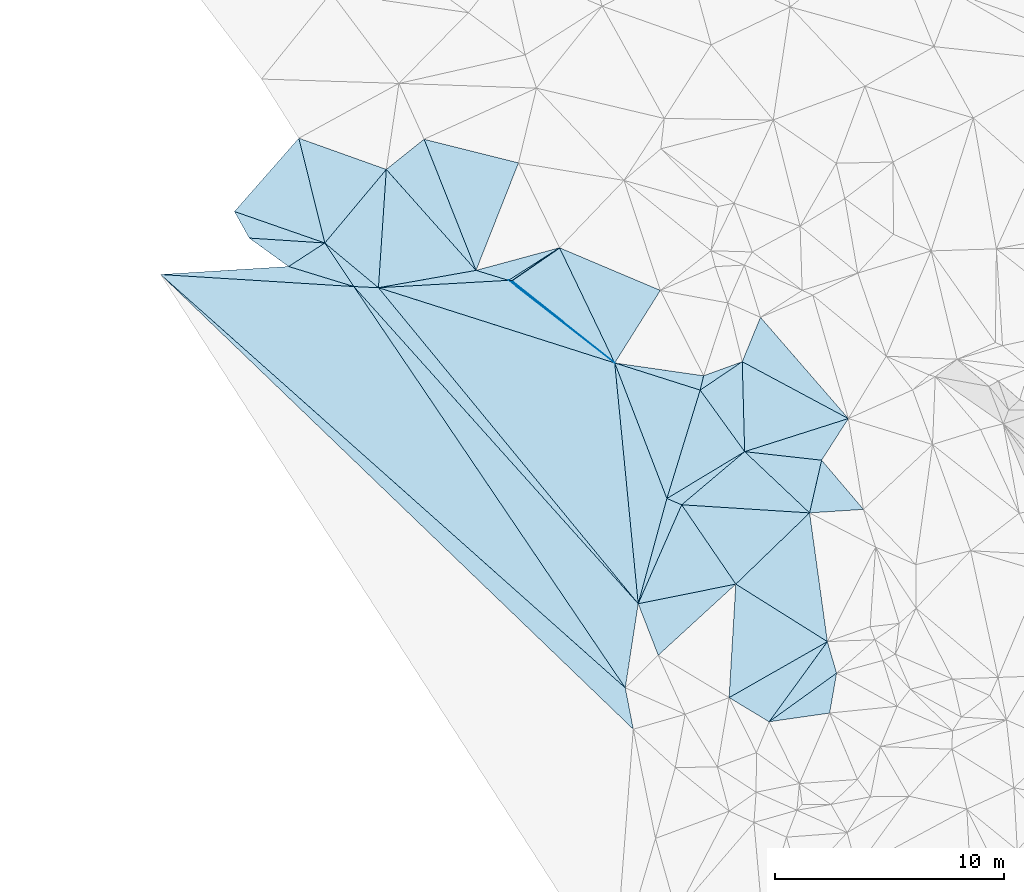
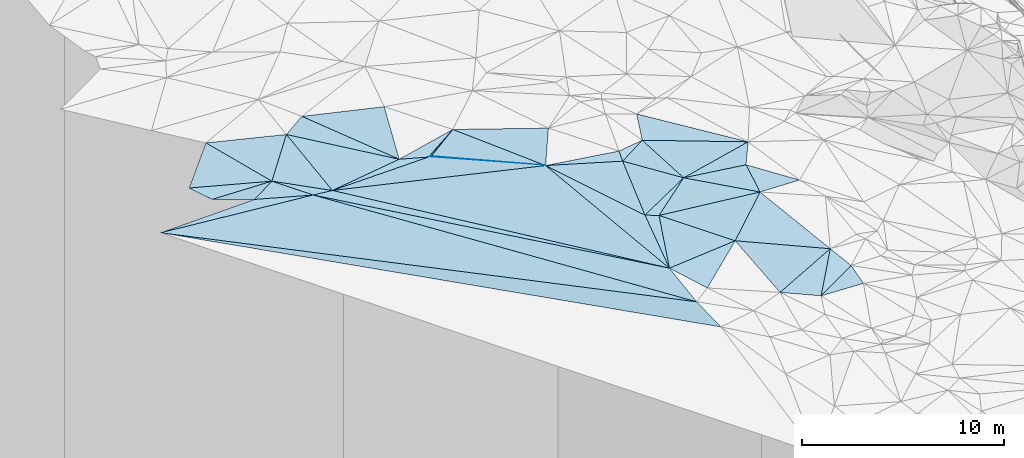
# One storey, part 10 of 275: 45 plates.
"""IFC2X3 building model written with IfcOpenShell, lengths in millimetres."""

from ifc_helpers import new_model, si_unit, frame, origin_with_axes, place, context, subcontext, project, spatial, polyline, outline, extrude, material, type_object, element, save


model = new_model("IFC2X3")

# Units and contexts
model_context = context("Model", 3, precision=1e-05, world=origin_with_axes())
body_context = subcontext(model_context, "Body", "Model", "MODEL_VIEW")
ifc_project = project(units=[si_unit("LENGTHUNIT", "METRE", prefix="MILLI"), si_unit("AREAUNIT", "SQUARE_METRE"), si_unit("VOLUMEUNIT", "CUBIC_METRE"), si_unit("MASSUNIT", "GRAM", prefix="KILO"), si_unit("TIMEUNIT", "SECOND"), si_unit("PLANEANGLEUNIT", "RADIAN"), si_unit("SOLIDANGLEUNIT", "STERADIAN"), si_unit("THERMODYNAMICTEMPERATUREUNIT", "DEGREE_CELSIUS"), si_unit("LUMINOUSINTENSITYUNIT", "LUMEN")], contexts=[model_context])

# Site, building, storey
site_placement = place(None, origin_with_axes())
site = spatial("IfcSite", under=ifc_project, at=site_placement, CompositionType="ELEMENT")
building_placement = place(site_placement, origin_with_axes())
building = spatial("IfcBuilding", under=site, at=building_placement, Name="Undefined", CompositionType="ELEMENT")
storey_placement = place(building_placement, origin_with_axes())
storey = spatial("IfcBuildingStorey", under=building, at=storey_placement, Name="Undefined", CompositionType="ELEMENT", Elevation=0.0)

# Plates
ifc_material = material()
plate_type_1 = type_object("IfcPlateType", PredefinedType="NOTDEFINED")
plate_1_placement = place(storey_placement, frame((-129497.98944048, 30765.4203278854, 46839.5020352332), z_axis=(0.057981187811851, -0.0697690065833723, -0.995876733125288), x_axis=(0.842744180886852, 0.538194366656215, 0.0113608662022535)))
element("IfcPlate", 1, at=plate_1_placement, inside=storey, type_object=plate_type_1, material=ifc_material, Name="00", context=body_context, shape_type="SweptSolid", body=[
    extrude(outline(polyline([(0.0, 0.0), (2640.64379882813, 4.32191882282496e-09), (106.60279083252, 97.6516571044922), (0.0, 0.0)])), frame((-8.85201319254618e-08, 2.18876761149539e-07, -0.5000001331573), z_axis=(0.0, 0.0, 1.0), x_axis=(1.0, 0.0, 0.0)), (0.0, 0.0, 1.0), 1.0),
])
plate_type_2 = type_object("IfcPlateType", PredefinedType="NOTDEFINED")
plate_2_placement = place(storey_placement, frame((-140809.419800372, 32609.296453986, 47119.5102054351), z_axis=(0.0366322844317989, 0.197863868701797, -0.979544774474177), x_axis=(-0.479506587570153, 0.863473031622803, 0.156485641951436)))
element("IfcPlate", 2, at=plate_2_placement, inside=storey, type_object=plate_type_2, material=ifc_material, Name="00", context=body_context, shape_type="SweptSolid", body=[
    extrude(outline(polyline([(0.0, 0.0), (1341.97619628906, -7.69796315580606e-09), (-1754.42761230469, 2802.53173828125), (0.0, 0.0)])), frame((-8.85201319254618e-08, 2.18876761149539e-07, -0.5000001331573), z_axis=(0.0, 0.0, 1.0), x_axis=(1.0, 0.0, 0.0)), (0.0, 0.0, 1.0), 1.0),
])
plate_type_3 = type_object("IfcPlateType", PredefinedType="NOTDEFINED")
plate_3_placement = place(storey_placement, frame((-115186.898183382, 13628.7321359164, 45659.505493286), z_axis=(-0.146868596418924, -0.0199757192000354, -0.988954289150099), x_axis=(-0.170723624477364, -0.984280047524368, 0.045235296956477)))
element("IfcPlate", 3, at=plate_3_placement, inside=storey, type_object=plate_type_3, material=ifc_material, Name="00", context=body_context, shape_type="SweptSolid", body=[
    extrude(outline(polyline([(0.0, 0.0), (1768.53051757813, 8.73114913702011e-11), (2612.28173828125, 2563.47094726563), (0.0, 0.0)])), frame((-8.85201319254618e-08, 2.18876761149539e-07, -0.5000001331573), z_axis=(0.0, 0.0, 1.0), x_axis=(1.0, 0.0, 0.0)), (0.0, 0.0, 1.0), 1.0),
])
plate_type_4 = type_object("IfcPlateType", PredefinedType="NOTDEFINED")
plate_4_placement = place(storey_placement, frame((-136244.554453764, 30494.4167340226, 47069.5011180862), z_axis=(-0.0617956592439033, 0.0270720044025747, -0.997721605998506), x_axis=(-0.953826144430841, 0.29278631743481, 0.0670213288674469)))
element("IfcPlate", 4, at=plate_4_placement, inside=storey, type_object=plate_type_4, material=ifc_material, Name="00", context=body_context, shape_type="SweptSolid", body=[
    extrude(outline(polyline([(0.0, 0.0), (2984.12475585938, -7.31779437046498e-09), (1773.04919433594, 1444.9208984375), (0.0, 0.0)])), frame((-8.85201319254618e-08, 2.18876761149539e-07, -0.5000001331573), z_axis=(0.0, 0.0, 1.0), x_axis=(1.0, 0.0, 0.0)), (0.0, 0.0, 1.0), 1.0),
])
plate_type_5 = type_object("IfcPlateType", PredefinedType="NOTDEFINED")
plate_5_placement = place(storey_placement, frame((-120987.42116318, 26601.1872303956, 46749.5193984975), z_axis=(0.00514777234642593, 0.275952058057676, -0.961157615635231), x_axis=(-0.225682846420036, -0.936051686110689, -0.269952762091974)))
element("IfcPlate", 5, at=plate_5_placement, inside=storey, type_object=plate_type_5, material=ifc_material, Name="00", context=body_context, shape_type="SweptSolid", body=[
    extrude(outline(polyline([(0.0, 0.0), (666.783325195313, -2.3283064365387e-10), (313.145202636719, 3907.72827148438), (0.0, 0.0)])), frame((-8.85201319254618e-08, 2.18876761149539e-07, -0.5000001331573), z_axis=(0.0, 0.0, 1.0), x_axis=(1.0, 0.0, 0.0)), (0.0, 0.0, 1.0), 1.0),
])
plate_type_6 = type_object("IfcPlateType", PredefinedType="NOTDEFINED")
plate_6_placement = place(storey_placement, frame((-121138.047902238, 25977.0698260404, 46569.5497685643), z_axis=(-0.285231675385021, 0.328447759598759, -0.900424877805811), x_axis=(0.225682846336975, 0.93605168613306, 0.269952762083846)))
element("IfcPlate", 6, at=plate_6_placement, inside=storey, type_object=plate_type_6, material=ifc_material, Name="00", context=body_context, shape_type="SweptSolid", body=[
    extrude(outline(polyline([(0.0, 0.0), (666.783325195313, -2.3283064365387e-10), (1538.28088378906, 1598.46557617188), (0.0, 0.0)])), frame((-8.85201319254618e-08, 2.18876761149539e-07, -0.5000001331573), z_axis=(0.0, 0.0, 1.0), x_axis=(1.0, 0.0, 0.0)), (0.0, 0.0, 1.0), 1.0),
])
plate_type_7 = type_object("IfcPlateType", PredefinedType="NOTDEFINED")
plate_7_placement = place(storey_placement, frame((-124865.001966316, 27160.9865014936, 46889.5028896927), z_axis=(-0.0956617096486233, -0.0497860347588166, -0.994168088428761), x_axis=(-0.432054029545914, 0.901840581725861, -0.00358896997731569)))
element("IfcPlate", 7, at=plate_7_placement, inside=storey, type_object=plate_type_7, material=ifc_material, Name="00", context=body_context, shape_type="SweptSolid", body=[
    extrude(outline(polyline([(0.0, 0.0), (5572.62939453125, 1.41444616019726e-08), (1995.70056152344, 3180.845703125), (0.0, 0.0)])), frame((-8.85201319254618e-08, 2.18876761149539e-07, -0.5000001331573), z_axis=(0.0, 0.0, 1.0), x_axis=(1.0, 0.0, 0.0)), (0.0, 0.0, 1.0), 1.0),
])
plate_type_8 = type_object("IfcPlateType", PredefinedType="NOTDEFINED")
plate_8_placement = place(storey_placement, frame((-130914.651502077, 31199.7287515079, 46939.5045032382), z_axis=(-0.119445783409345, -0.0611835406095751, -0.990953722019451), x_axis=(-0.664054268606108, 0.746914264676297, 0.0339265319340748)))
element("IfcPlate", 8, at=plate_8_placement, inside=storey, type_object=plate_type_8, material=ifc_material, Name="00", context=body_context, shape_type="SweptSolid", body=[
    extrude(outline(polyline([(0.0, 0.0), (5895.09130859375, -4.23315213993192e-08), (5776.5859375, 2125.45434570313), (0.0, 0.0)])), frame((-8.85201319254618e-08, 2.18876761149539e-07, -0.5000001331573), z_axis=(0.0, 0.0, 1.0), x_axis=(1.0, 0.0, 0.0)), (0.0, 0.0, 1.0), 1.0),
])
plate_type_9 = type_object("IfcPlateType", PredefinedType="NOTDEFINED")
plate_9_placement = place(storey_placement, frame((-124864.910778132, 27161.0602506427, 46889.5042592127), z_axis=(0.0867178704583253, 0.0977121618071371, -0.99142944498242), x_axis=(-0.789245202864581, 0.614019105121283, -0.00851752906101246)))
element("IfcPlate", 9, at=plate_9_placement, inside=storey, type_object=plate_type_9, material=ifc_material, Name="00", context=body_context, shape_type="SweptSolid", body=[
    extrude(outline(polyline([(0.0, 0.0), (5870.2470703125, 1.09721440821886e-08), (5742.8759765625, 68.3856353759766), (0.0, 0.0)])), frame((-8.85201319254618e-08, 2.18876761149539e-07, -0.5000001331573), z_axis=(0.0, 0.0, 1.0), x_axis=(1.0, 0.0, 0.0)), (0.0, 0.0, 1.0), 1.0),
])
plate_type_10 = type_object("IfcPlateType", PredefinedType="NOTDEFINED")
plate_10_placement = place(storey_placement, frame((-121943.807238033, 20973.8726211017, 46599.5034278573), z_axis=(-0.092929890719079, 0.0715476258097807, -0.993098672163005), x_axis=(-0.915330244040877, 0.386381533399157, 0.113489448814346)))
element("IfcPlate", 10, at=plate_10_placement, inside=storey, type_object=plate_type_10, material=ifc_material, Name="00", context=body_context, shape_type="SweptSolid", body=[
    extrude(outline(polyline([(0.0, 0.0), (704.911315917969, 1.97906047105789e-09), (-1628.71545410156, 3205.92993164063), (0.0, 0.0)])), frame((-8.85201319254618e-08, 2.18876761149539e-07, -0.5000001331573), z_axis=(0.0, 0.0, 1.0), x_axis=(1.0, 0.0, 0.0)), (0.0, 0.0, 1.0), 1.0),
])
plate_type_11 = type_object("IfcPlateType", PredefinedType="NOTDEFINED")
plate_11_placement = place(storey_placement, frame((-144676.990805354, 31019.7064139136, 47419.5036823139), z_axis=(-0.03393144394055, 0.116672279413199, -0.992590669071918), x_axis=(0.997701745419558, 0.0622373826904291, -0.0267905838423331)))
element("IfcPlate", 11, at=plate_11_placement, inside=storey, type_object=plate_type_11, material=ifc_material, Name="00", context=body_context, shape_type="SweptSolid", body=[
    extrude(outline(polyline([(0.0, 0.0), (5598.98193359375, 8.0843165051192e-08), (8389.7568359375, 1056.6806640625), (0.0, 0.0)])), frame((-8.85201319254618e-08, 2.18876761149539e-07, -0.5000001331573), z_axis=(0.0, 0.0, 1.0), x_axis=(1.0, 0.0, 0.0)), (0.0, 0.0, 1.0), 1.0),
])
plate_type_12 = type_object("IfcPlateType", PredefinedType="NOTDEFINED")
plate_12_placement = place(storey_placement, frame((-137511.023158515, 32394.5908185045, 47199.5011040334), z_axis=(-0.0594436998427387, 0.0310280513005853, -0.997749320511668), x_axis=(0.64126766389933, 0.767183116906606, -0.0143474168602026)))
element("IfcPlate", 12, at=plate_12_placement, inside=storey, type_object=plate_type_12, material=ifc_material, Name="00", context=body_context, shape_type="SweptSolid", body=[
    extrude(outline(polyline([(0.0, 0.0), (4181.9375, -1.2732925824821e-08), (5.7389669418335, 3052.10864257813), (0.0, 0.0)])), frame((-8.85201319254618e-08, 2.18876761149539e-07, -0.5000001331573), z_axis=(0.0, 0.0, 1.0), x_axis=(1.0, 0.0, 0.0)), (0.0, 0.0, 1.0), 1.0),
])
plate_type_13 = type_object("IfcPlateType", PredefinedType="NOTDEFINED")
plate_13_placement = place(storey_placement, frame((-136244.556828728, 30494.3870080844, 47069.5013431176), z_axis=(-0.0666470124414277, -0.0323585151868557, -0.997251774742735), x_axis=(0.996759870239894, -0.0472684283976649, -0.0650803868777996)))
element("IfcPlate", 13, at=plate_13_placement, inside=storey, type_object=plate_type_13, material=ifc_material, Name="00", context=body_context, shape_type="SweptSolid", body=[
    extrude(outline(polyline([(0.0, 0.0), (1075.59289550781, 1.05064827948809e-08), (13042.2958984375, 13241.38671875), (0.0, 0.0)])), frame((-8.85201319254618e-08, 2.18876761149539e-07, -0.5000001331573), z_axis=(0.0, 0.0, 1.0), x_axis=(1.0, 0.0, 0.0)), (0.0, 0.0, 1.0), 1.0),
])
plate_type_14 = type_object("IfcPlateType", PredefinedType="NOTDEFINED")
plate_14_placement = place(storey_placement, frame((-116364.133601704, 20619.7169646685, 46279.501426344), z_axis=(-0.0617568766557274, 0.0447250853473435, -0.997088639453084), x_axis=(0.136852615654429, -0.989180769234496, -0.0528466400558436)))
element("IfcPlate", 14, at=plate_14_placement, inside=storey, type_object=plate_type_14, material=ifc_material, Name="00", context=body_context, shape_type="SweptSolid", body=[
    extrude(outline(polyline([(0.0, 0.0), (5676.8037109375, -4.10364009439945e-09), (2629.47265625, 3619.54052734375), (0.0, 0.0)])), frame((-8.85201319254618e-08, 2.18876761149539e-07, -0.5000001331573), z_axis=(0.0, 0.0, 1.0), x_axis=(1.0, 0.0, 0.0)), (0.0, 0.0, 1.0), 1.0),
])
plate_type_15 = type_object("IfcPlateType", PredefinedType="NOTDEFINED")
plate_15_placement = place(storey_placement, frame((-115838.75793992, 22918.4513374897, 46349.502350899), z_axis=(-0.0837248677699434, 0.0494430140865863, -0.99526154094034), x_axis=(0.644770726207681, -0.758826841202199, -0.0919376728915456)))
element("IfcPlate", 15, at=plate_15_placement, inside=storey, type_object=plate_type_15, material=ifc_material, Name="00", context=body_context, shape_type="SweptSolid", body=[
    extrude(outline(polyline([(0.0, 0.0), (2828.0029296875, 3.94356902688742e-09), (1412.02124023438, 1889.78735351563), (0.0, 0.0)])), frame((-8.85201319254618e-08, 2.18876761149539e-07, -0.5000001331573), z_axis=(0.0, 0.0, 1.0), x_axis=(1.0, 0.0, 0.0)), (0.0, 0.0, 1.0), 1.0),
])
plate_type_16 = type_object("IfcPlateType", PredefinedType="NOTDEFINED")
plate_16_placement = place(storey_placement, frame((-124864.982738049, 27161.0181105779, 46889.5008377199), z_axis=(-0.0572027945096327, 0.0134316247717248, -0.998272223271929), x_axis=(0.358925021676741, -0.932778678031809, -0.0331174670465846)))
element("IfcPlate", 16, at=plate_16_placement, inside=storey, type_object=plate_type_16, material=ifc_material, Name="00", context=body_context, shape_type="SweptSolid", body=[
    extrude(outline(polyline([(0.0, 0.0), (6341.064453125, -5.20958565175533e-09), (10170.9580078125, 2819.24072265625), (0.0, 0.0)])), frame((-8.85201319254618e-08, 2.18876761149539e-07, -0.5000001331573), z_axis=(0.0, 0.0, 1.0), x_axis=(1.0, 0.0, 0.0)), (0.0, 0.0, 1.0), 1.0),
])
plate_type_17 = type_object("IfcPlateType", PredefinedType="NOTDEFINED")
plate_17_placement = place(storey_placement, frame((-129498.031226279, 30765.4319043985, 46839.5006869652), z_axis=(-0.0255109960154324, -0.0466433609721106, -0.998585792989028), x_axis=(0.789245202894416, -0.614019105082597, 0.0085175290852498)))
element("IfcPlate", 17, at=plate_17_placement, inside=storey, type_object=plate_type_17, material=ifc_material, Name="00", context=body_context, shape_type="SweptSolid", body=[
    extrude(outline(polyline([(0.0, 0.0), (5870.2470703125, 1.09721440821886e-08), (-4279.47900390625, 3743.53540039063), (0.0, 0.0)])), frame((-8.85201319254618e-08, 2.18876761149539e-07, -0.5000001331573), z_axis=(0.0, 0.0, 1.0), x_axis=(1.0, 0.0, 0.0)), (0.0, 0.0, 1.0), 1.0),
])
plate_type_18 = type_object("IfcPlateType", PredefinedType="NOTDEFINED")
plate_18_placement = place(storey_placement, frame((-114673.617685681, 24734.6110711652, 46229.5009122159), z_axis=(-0.0512434124664207, -0.0330754520848512, -0.998138330667738), x_axis=(-0.539126231583638, -0.840392601573042, 0.0555264048874096)))
element("IfcPlate", 18, at=plate_18_placement, inside=storey, type_object=plate_type_18, material=ifc_material, Name="00", context=body_context, shape_type="SweptSolid", body=[
    extrude(outline(polyline([(0.0, 0.0), (2161.13403320313, 5.19503373652697e-09), (3665.9921875, 3029.42260742188), (0.0, 0.0)])), frame((-8.85201319254618e-08, 2.18876761149539e-07, -0.5000001331573), z_axis=(0.0, 0.0, 1.0), x_axis=(1.0, 0.0, 0.0)), (0.0, 0.0, 1.0), 1.0),
])
plate_type_19 = type_object("IfcPlateType", PredefinedType="NOTDEFINED")
plate_19_placement = place(storey_placement, frame((-135172.447673114, 30443.5744249112, 46999.5011596011), z_axis=(-0.0639205569554551, 0.0256491670470696, -0.99762532176579), x_axis=(-0.996759870241943, 0.0472684283917526, 0.065080386850713)))
element("IfcPlate", 19, at=plate_19_placement, inside=storey, type_object=plate_type_19, material=ifc_material, Name="00", context=body_context, shape_type="SweptSolid", body=[
    extrude(outline(polyline([(0.0, 0.0), (1075.59289550781, 1.05064827948809e-08), (2436.23779296875, 1838.51708984375), (0.0, 0.0)])), frame((-8.85201319254618e-08, 2.18876761149539e-07, -0.5000001331573), z_axis=(0.0, 0.0, 1.0), x_axis=(1.0, 0.0, 0.0)), (0.0, 0.0, 1.0), 1.0),
])
plate_type_20 = type_object("IfcPlateType", PredefinedType="NOTDEFINED")
plate_20_placement = place(storey_placement, frame((-123840.83662912, 16658.2844530237, 46689.5032737865), z_axis=(-0.111266888319396, 0.0281933773244981, -0.993390564198572), x_axis=(0.263222440539984, 0.964732877634244, -0.00210276192820028)))
element("IfcPlate", 20, at=plate_20_placement, inside=storey, type_object=plate_type_20, material=ifc_material, Name="00", context=body_context, shape_type="SweptSolid", body=[
    extrude(outline(polyline([(0.0, 0.0), (4755.6494140625, 1.89174897968769e-09), (4662.896484375, 698.782470703125), (0.0, 0.0)])), frame((-8.85201319254618e-08, 2.18876761149539e-07, -0.5000001331573), z_axis=(0.0, 0.0, 1.0), x_axis=(1.0, 0.0, 0.0)), (0.0, 0.0, 1.0), 1.0),
])
plate_type_21 = type_object("IfcPlateType", PredefinedType="NOTDEFINED")
plate_21_placement = place(storey_placement, frame((-119582.791088324, 17512.975257719, 46339.5010734237), z_axis=(-0.0548412702306385, 0.0375468144239046, -0.997788891402439), x_axis=(-0.562467486695113, 0.824496021808755, 0.0619405879243933)))
element("IfcPlate", 21, at=plate_21_placement, inside=storey, type_object=plate_type_21, material=ifc_material, Name="00", context=body_context, shape_type="SweptSolid", body=[
    extrude(outline(polyline([(0.0, 0.0), (4197.57080078125, 9.89530235528946e-10), (747.384643554688, 4410.96533203125), (0.0, 0.0)])), frame((-8.85201319254618e-08, 2.18876761149539e-07, -0.5000001331573), z_axis=(0.0, 0.0, 1.0), x_axis=(1.0, 0.0, 0.0)), (0.0, 0.0, 1.0), 1.0),
])
plate_type_22 = type_object("IfcPlateType", PredefinedType="NOTDEFINED")
plate_22_placement = place(storey_placement, frame((-123840.823623992, 16658.2787128686, 46689.5018565725), z_axis=(-0.0852378433253033, 0.0166926054842784, -0.996220792288234), x_axis=(0.402340221376061, 0.915291204244876, -0.0190881558833484)))
element("IfcPlate", 22, at=plate_22_placement, inside=storey, type_object=plate_type_22, material=ifc_material, Name="00", context=body_context, shape_type="SweptSolid", body=[
    extrude(outline(polyline([(0.0, 0.0), (4714.96533203125, 1.51339918375015e-09), (2502.13916015625, 3566.93139648438), (0.0, 0.0)])), frame((-8.85201319254618e-08, 2.18876761149539e-07, -0.5000001331573), z_axis=(0.0, 0.0, 1.0), x_axis=(1.0, 0.0, 0.0)), (0.0, 0.0, 1.0), 1.0),
])
plate_type_23 = type_object("IfcPlateType", PredefinedType="NOTDEFINED")
plate_23_placement = place(storey_placement, frame((-123840.843916076, 16658.227521533, 46689.5057970128), z_axis=(-0.12584149748718, -0.0856695060396611, -0.988344400118251), x_axis=(-0.150908597419557, -0.983017084128588, 0.10442225594283)))
element("IfcPlate", 23, at=plate_23_placement, inside=storey, type_object=plate_type_23, material=ifc_material, Name="00", context=body_context, shape_type="SweptSolid", body=[
    extrude(outline(polyline([(0.0, 0.0), (3734.8359375, 7.91624188423157e-09), (-11689.6435546875, 14449.5), (0.0, 0.0)])), frame((-8.85201319254618e-08, 2.18876761149539e-07, -0.5000001331573), z_axis=(0.0, 0.0, 1.0), x_axis=(1.0, 0.0, 0.0)), (0.0, 0.0, 1.0), 1.0),
])
plate_type_24 = type_object("IfcPlateType", PredefinedType="NOTDEFINED")
plate_24_placement = place(storey_placement, frame((-130914.609058932, 31199.8172615305, 46939.5036459403), z_axis=(-0.0345611548002263, 0.115836509185112, -0.992666827147297), x_axis=(0.953905197885711, -0.292455711264389, -0.0673389218466002)))
element("IfcPlate", 24, at=plate_24_placement, inside=storey, type_object=plate_type_24, material=ifc_material, Name="00", context=body_context, shape_type="SweptSolid", body=[
    extrude(outline(polyline([(0.0, 0.0), (1485.02526855469, -2.97495716949925e-09), (-3844.4462890625, 1981.09362792969), (0.0, 0.0)])), frame((-8.85201319254618e-08, 2.18876761149539e-07, -0.5000001331573), z_axis=(0.0, 0.0, 1.0), x_axis=(1.0, 0.0, 0.0)), (0.0, 0.0, 1.0), 1.0),
])
plate_type_25 = type_object("IfcPlateType", PredefinedType="NOTDEFINED")
plate_25_placement = place(storey_placement, frame((-119582.805719339, 17512.9609746989, 46339.5017627495), z_axis=(-0.0841245527337085, 0.00900313879412917, -0.996414573919514), x_axis=(0.844452673194461, -0.530198723391855, -0.076085454906804)))
element("IfcPlate", 25, at=plate_25_placement, inside=storey, type_object=plate_type_25, material=ifc_material, Name="00", context=body_context, shape_type="SweptSolid", body=[
    extrude(outline(polyline([(0.0, 0.0), (4731.52197265625, -2.42289388552308e-08), (2379.25561523438, 4352.0732421875), (0.0, 0.0)])), frame((-8.85201319254618e-08, 2.18876761149539e-07, -0.5000001331573), z_axis=(0.0, 0.0, 1.0), x_axis=(1.0, 0.0, 0.0)), (0.0, 0.0, 1.0), 1.0),
])
plate_type_26 = type_object("IfcPlateType", PredefinedType="NOTDEFINED")
plate_26_placement = place(storey_placement, frame((-122966.963450287, 14409.6033073192, 46549.502082653), z_axis=(-0.087471385822707, 0.0280032652804688, -0.995773354632412), x_axis=(-0.361612562653735, 0.930526772978791, 0.0579334040142317)))
element("IfcPlate", 26, at=plate_26_placement, inside=storey, type_object=plate_type_26, material=ifc_material, Name="00", context=body_context, shape_type="SweptSolid", body=[
    extrude(outline(polyline([(0.0, 0.0), (2416.56787109375, -1.44063960760832e-09), (1651.84692382813, 4289.39404296875), (0.0, 0.0)])), frame((-8.85201319254618e-08, 2.18876761149539e-07, -0.5000001331573), z_axis=(0.0, 0.0, 1.0), x_axis=(1.0, 0.0, 0.0)), (0.0, 0.0, 1.0), 1.0),
])
plate_type_27 = type_object("IfcPlateType", PredefinedType="NOTDEFINED")
plate_27_placement = place(storey_placement, frame((-124404.261081209, 12987.0272748802, 47079.5486660799), z_axis=(0.277550202776657, 0.329041957684382, -0.902605824832671), x_axis=(0.181948393606104, -0.940518546833353, -0.28691400301595)))
element("IfcPlate", 27, at=plate_27_placement, inside=storey, type_object=plate_type_27, material=ifc_material, Name="00", context=body_context, shape_type="SweptSolid", body=[
    extrude(outline(polyline([(0.0, 0.0), (1916.95068359375, -7.27595761418343e-10), (-20746.28125, 17489.025390625), (0.0, 0.0)])), frame((-8.85201319254618e-08, 2.18876761149539e-07, -0.5000001331573), z_axis=(0.0, 0.0, 1.0), x_axis=(1.0, 0.0, 0.0)), (0.0, 0.0, 1.0), 1.0),
])
plate_type_28 = type_object("IfcPlateType", PredefinedType="NOTDEFINED")
plate_28_placement = place(storey_placement, frame((-115587.347730005, 15004.3826018434, 45979.5228407674), z_axis=(-0.260868246150556, 0.146058923923173, -0.954261258195437), x_axis=(0.27275481367161, -0.93706200704933, -0.217989923078219)))
element("IfcPlate", 28, at=plate_28_placement, inside=storey, type_object=plate_type_28, material=ifc_material, Name="00", context=body_context, shape_type="SweptSolid", body=[
    extrude(outline(polyline([(0.0, 0.0), (1467.95776367188, 4.75847627967596e-09), (2548.30224609375, 3496.89233398438), (0.0, 0.0)])), frame((-8.85201319254618e-08, 2.18876761149539e-07, -0.5000001331573), z_axis=(0.0, 0.0, 1.0), x_axis=(1.0, 0.0, 0.0)), (0.0, 0.0, 1.0), 1.0),
])
plate_type_29 = type_object("IfcPlateType", PredefinedType="NOTDEFINED")
plate_29_placement = place(storey_placement, frame((-134829.254814466, 35602.8798345858, 47139.5000373486), z_axis=(-0.00514224816019048, -0.0144009710524155, -0.999883077822906), x_axis=(-0.641267664487795, -0.767183116414906, 0.0143474168505088)))
element("IfcPlate", 29, at=plate_29_placement, inside=storey, type_object=plate_type_29, material=ifc_material, Name="00", context=body_context, shape_type="SweptSolid", body=[
    extrude(outline(polyline([(0.0, 0.0), (4181.9375, -1.2732925824821e-08), (1402.10131835938, 3802.86889648438), (0.0, 0.0)])), frame((-8.85201319254618e-08, 2.18876761149539e-07, -0.5000001331573), z_axis=(0.0, 0.0, 1.0), x_axis=(1.0, 0.0, 0.0)), (0.0, 0.0, 1.0), 1.0),
])
plate_type_30 = type_object("IfcPlateType", PredefinedType="NOTDEFINED")
plate_30_placement = place(storey_placement, frame((-144676.995451351, 31019.6331375192, 47419.5006596199), z_axis=(-0.0433087602669717, -0.0298595477366366, -0.998615420816793), x_axis=(0.99721039891979, -0.0621147633784265, -0.0413905358345987)))
element("IfcPlate", 30, at=plate_30_placement, inside=storey, type_object=plate_type_30, material=ifc_material, Name="00", context=body_context, shape_type="SweptSolid", body=[
    extrude(outline(polyline([(0.0, 0.0), (8456.0390625, 7.2868715506047e-09), (21350.197265625, 16746.44140625), (0.0, 0.0)])), frame((-8.85201319254618e-08, 2.18876761149539e-07, -0.5000001331573), z_axis=(0.0, 0.0, 1.0), x_axis=(1.0, 0.0, 0.0)), (0.0, 0.0, 1.0), 1.0),
])
plate_type_31 = type_object("IfcPlateType", PredefinedType="NOTDEFINED")
plate_31_placement = place(storey_placement, frame((-127272.626546254, 32186.6350944726, 46869.4999955876), z_axis=(0.00927706652484839, 0.000465025457383904, -0.999956858963434), x_axis=(0.432054029546703, -0.901840581725484, 0.00358896997731434)))
element("IfcPlate", 31, at=plate_31_placement, inside=storey, type_object=plate_type_31, material=ifc_material, Name="00", context=body_context, shape_type="SweptSolid", body=[
    extrude(outline(polyline([(0.0, 0.0), (5572.62939453125, 1.41444616019726e-08), (403.741180419922, 2503.576171875), (0.0, 0.0)])), frame((-8.85201319254618e-08, 2.18876761149539e-07, -0.5000001331573), z_axis=(0.0, 0.0, 1.0), x_axis=(1.0, 0.0, 0.0)), (0.0, 0.0, 1.0), 1.0),
])
plate_type_32 = type_object("IfcPlateType", PredefinedType="NOTDEFINED")
plate_32_placement = place(storey_placement, frame((-130914.61329516, 31199.803586885, 46939.5024024933), z_axis=(-0.0431122770185451, 0.0885150254081129, -0.995141407965359), x_axis=(0.965026133413332, 0.261496703474337, -0.0185482048017892)))
element("IfcPlate", 32, at=plate_32_placement, inside=storey, type_object=plate_type_32, material=ifc_material, Name="00", context=body_context, shape_type="SweptSolid", body=[
    extrude(outline(polyline([(0.0, 0.0), (3773.9501953125, -1.31403794512153e-08), (1255.31604003906, 793.398864746094), (0.0, 0.0)])), frame((-8.85201319254618e-08, 2.18876761149539e-07, -0.5000001331573), z_axis=(0.0, 0.0, 1.0), x_axis=(1.0, 0.0, 0.0)), (0.0, 0.0, 1.0), 1.0),
])
plate_type_33 = type_object("IfcPlateType", PredefinedType="NOTDEFINED")
plate_33_placement = place(storey_placement, frame((-119301.783511417, 27215.0617801086, 46439.5008462051), z_axis=(-0.0556416557718517, -0.0193042930285978, -0.998264168651581), x_axis=(0.880691082278684, -0.472002491508834, -0.0399608008459917)))
element("IfcPlate", 33, at=plate_33_placement, inside=storey, type_object=plate_type_33, material=ifc_material, Name="00", context=body_context, shape_type="SweptSolid", body=[
    extrude(outline(polyline([(0.0, 0.0), (5255.14990234375, -1.40971678774804e-08), (1941.10546875, 3410.86645507813), (0.0, 0.0)])), frame((-8.85201319254618e-08, 2.18876761149539e-07, -0.5000001331573), z_axis=(0.0, 0.0, 1.0), x_axis=(1.0, 0.0, 0.0)), (0.0, 0.0, 1.0), 1.0),
])
plate_type_34 = type_object("IfcPlateType", PredefinedType="NOTDEFINED")
plate_34_placement = place(storey_placement, frame((-118130.467747527, 11507.3771160997, 46139.5021342309), z_axis=(-0.0904644295359098, 0.0202344039659583, -0.995694107587709), x_axis=(-0.852636080543345, 0.515052799541779, 0.0879336558995366)))
element("IfcPlate", 34, at=plate_34_placement, inside=storey, type_object=plate_type_34, material=ifc_material, Name="00", context=body_context, shape_type="SweptSolid", body=[
    extrude(outline(polyline([(0.0, 0.0), (2046.99780273438, -8.60745785757899e-09), (-381.387817382813, 4310.06298828125), (0.0, 0.0)])), frame((-8.85201319254618e-08, 2.18876761149539e-07, -0.5000001331573), z_axis=(0.0, 0.0, 1.0), x_axis=(1.0, 0.0, 0.0)), (0.0, 0.0, 1.0), 1.0),
])
plate_type_35 = type_object("IfcPlateType", PredefinedType="NOTDEFINED")
plate_35_placement = place(storey_placement, frame((-134829.261799806, 35602.9012313138, 47139.5002716614), z_axis=(-0.019125839404455, 0.0283915476561313, -0.999413889381554), x_axis=(0.664054268608167, -0.74691426467427, -0.0339265319384026)))
element("IfcPlate", 35, at=plate_35_placement, inside=storey, type_object=plate_type_35, material=ifc_material, Name="00", context=body_context, shape_type="SweptSolid", body=[
    extrude(outline(polyline([(0.0, 0.0), (5895.09130859375, -4.23315213993192e-08), (3630.4443359375, 3684.54541015625), (0.0, 0.0)])), frame((-8.85201319254618e-08, 2.18876761149539e-07, -0.5000001331573), z_axis=(0.0, 0.0, 1.0), x_axis=(1.0, 0.0, 0.0)), (0.0, 0.0, 1.0), 1.0),
])
plate_type_36 = type_object("IfcPlateType", PredefinedType="NOTDEFINED")
plate_36_placement = place(storey_placement, frame((-138646.336449166, 36965.8591833204, 47139.5005360068), z_axis=(-0.0410629465026348, -0.0233090959172516, -0.998884638220071), x_axis=(0.241016868653466, -0.970437338862926, 0.0127373609951196)))
element("IfcPlate", 36, at=plate_36_placement, inside=storey, type_object=plate_type_36, material=ifc_material, Name="00", context=body_context, shape_type="SweptSolid", body=[
    extrude(outline(polyline([(0.0, 0.0), (4710.5517578125, 6.06814865022898e-09), (2429.35424804688, 3498.29052734375), (0.0, 0.0)])), frame((-8.85201319254618e-08, 2.18876761149539e-07, -0.5000001331573), z_axis=(0.0, 0.0, 1.0), x_axis=(1.0, 0.0, 0.0)), (0.0, 0.0, 1.0), 1.0),
])
plate_type_37 = type_object("IfcPlateType", PredefinedType="NOTDEFINED")
plate_37_placement = place(storey_placement, frame((-114673.59477533, 24734.6647642846, 46229.501371188), z_axis=(-0.00542189128414873, 0.0743104451294681, -0.997220417380011), x_axis=(-0.880691082327148, 0.472002491414667, 0.0399608008901741)))
element("IfcPlate", 37, at=plate_37_placement, inside=storey, type_object=plate_type_37, material=ifc_material, Name="00", context=body_context, shape_type="SweptSolid", body=[
    extrude(outline(polyline([(0.0, 0.0), (5255.14990234375, -1.40971678774804e-08), (5474.953125, 2086.59692382813), (0.0, 0.0)])), frame((-8.85201319254618e-08, 2.18876761149539e-07, -0.5000001331573), z_axis=(0.0, 0.0, 1.0), x_axis=(1.0, 0.0, 0.0)), (0.0, 0.0, 1.0), 1.0),
])
plate_38_placement = place(storey_placement, frame((-119301.784489745, 27215.061756406, 46439.5009057419), z_axis=(-0.0576177058164571, -0.0193551714891384, -0.99815107940285), x_axis=(0.026755485657251, -0.999482867005349, 0.0178365509562134)))
element("IfcPlate", 38, at=plate_38_placement, inside=storey, type_object=plate_type_37, material=ifc_material, Name="00", context=body_context, shape_type="SweptSolid", body=[
    extrude(outline(polyline([(0.0, 0.0), (3924.525390625, 2.66300048679113e-09), (1190.71716308594, 1871.78857421875), (0.0, 0.0)])), frame((-8.85201319254618e-08, 2.18876761149539e-07, -0.5000001331573), z_axis=(0.0, 0.0, 1.0), x_axis=(1.0, 0.0, 0.0)), (0.0, 0.0, 1.0), 1.0),
])
plate_type_38 = type_object("IfcPlateType", PredefinedType="NOTDEFINED")
plate_39_placement = place(storey_placement, frame((-129062.561249848, 35889.0422139166, 46629.5014603351), z_axis=(-0.0656885977110086, -0.039968151447872, -0.997039394909048), x_axis=(-0.366649627477696, -0.928332783458513, 0.0613701379062857)))
element("IfcPlate", 39, at=plate_39_placement, inside=storey, type_object=plate_type_38, material=ifc_material, Name="00", context=body_context, shape_type="SweptSolid", body=[
    extrude(outline(polyline([(0.0, 0.0), (5051.31689453125, -1.08557287603617e-08), (565.872253417969, 4215.1259765625), (0.0, 0.0)])), frame((-8.85201319254618e-08, 2.18876761149539e-07, -0.5000001331573), z_axis=(0.0, 0.0, 1.0), x_axis=(1.0, 0.0, 0.0)), (0.0, 0.0, 1.0), 1.0),
])
plate_type_39 = type_object("IfcPlateType", PredefinedType="NOTDEFINED")
plate_40_placement = place(storey_placement, frame((-121137.927402837, 25976.9007722333, 46569.5004938958), z_axis=(-0.0442357982186686, -0.00965974766290037, -0.998974415804052), x_axis=(0.585884245430343, -0.810192385461185, -0.0181093759481662)))
element("IfcPlate", 40, at=plate_40_placement, inside=storey, type_object=plate_type_39, material=ifc_material, Name="00", context=body_context, shape_type="SweptSolid", body=[
    extrude(outline(polyline([(0.0, 0.0), (3313.20092773438, -1.07393134385347e-08), (2980.6220703125, 3951.35302734375), (0.0, 0.0)])), frame((-8.85201319254618e-08, 2.18876761149539e-07, -0.5000001331573), z_axis=(0.0, 0.0, 1.0), x_axis=(1.0, 0.0, 0.0)), (0.0, 0.0, 1.0), 1.0),
])
plate_type_40 = type_object("IfcPlateType", PredefinedType="NOTDEFINED")
plate_41_placement = place(storey_placement, frame((-123840.783419733, 16658.2796545242, 46689.5000717593), z_axis=(-0.0047542889514534, 0.0185755330571326, -0.999816156254843), x_axis=(-0.634911364582126, 0.772389711663009, 0.0173692959441875)))
element("IfcPlate", 41, at=plate_41_placement, inside=storey, type_object=plate_type_40, material=ifc_material, Name="00", context=body_context, shape_type="SweptSolid", body=[
    extrude(outline(polyline([(0.0, 0.0), (17847.5859375, 4.26371116191149e-09), (8765.9423828125, 5878.32958984375), (0.0, 0.0)])), frame((-8.85201319254618e-08, 2.18876761149539e-07, -0.5000001331573), z_axis=(0.0, 0.0, 1.0), x_axis=(1.0, 0.0, 0.0)), (0.0, 0.0, 1.0), 1.0),
])
plate_type_41 = type_object("IfcPlateType", PredefinedType="NOTDEFINED")
plate_42_placement = place(storey_placement, frame((-137510.984476124, 32394.5275715308, 47199.5023426025), z_axis=(0.017927426174395, -0.0954657815648877, -0.995271265505524), x_axis=(-0.837974993812734, -0.544444097664598, 0.0371286178402876)))
element("IfcPlate", 42, at=plate_42_placement, inside=storey, type_object=plate_type_41, material=ifc_material, Name="00", context=body_context, shape_type="SweptSolid", body=[
    extrude(outline(polyline([(0.0, 0.0), (1885.33813476563, -1.05646904557943e-08), (2644.19409179688, 1985.05358886719), (0.0, 0.0)])), frame((-8.85201319254618e-08, 2.18876761149539e-07, -0.5000001331573), z_axis=(0.0, 0.0, 1.0), x_axis=(1.0, 0.0, 0.0)), (0.0, 0.0, 1.0), 1.0),
])
plate_type_42 = type_object("IfcPlateType", PredefinedType="NOTDEFINED")
plate_43_placement = place(storey_placement, frame((-116364.124315942, 20619.7147362759, 46279.5008515593), z_axis=(-0.0430799859388104, 0.0402447537115138, -0.998260724765936), x_axis=(-0.726055711802598, 0.685104126835292, 0.0589528519418368)))
element("IfcPlate", 43, at=plate_43_placement, inside=storey, type_object=plate_type_42, material=ifc_material, Name="00", context=body_context, shape_type="SweptSolid", body=[
    extrude(outline(polyline([(0.0, 0.0), (3901.4228515625, 1.87355908565223e-08), (1197.53747558594, 2032.48718261719), (0.0, 0.0)])), frame((-8.85201319254618e-08, 2.18876761149539e-07, -0.5000001331573), z_axis=(0.0, 0.0, 1.0), x_axis=(1.0, 0.0, 0.0)), (0.0, 0.0, 1.0), 1.0),
])
plate_type_43 = type_object("IfcPlateType", PredefinedType="NOTDEFINED")
plate_44_placement = place(storey_placement, frame((-116364.130535818, 20619.7081345076, 46279.5009365838), z_axis=(-0.0555254180958117, 0.0270408032249175, -0.998091039387809), x_axis=(-0.996361143769444, 0.063239281318026, 0.0571424928124869)))
element("IfcPlate", 44, at=plate_44_placement, inside=storey, type_object=plate_type_43, material=ifc_material, Name="00", context=body_context, shape_type="SweptSolid", body=[
    extrude(outline(polyline([(0.0, 0.0), (5600.03564453125, 1.75059540197253e-08), (3004.5166015625, 2488.77075195313), (0.0, 0.0)])), frame((-8.85201319254618e-08, 2.18876761149539e-07, -0.5000001331573), z_axis=(0.0, 0.0, 1.0), x_axis=(1.0, 0.0, 0.0)), (0.0, 0.0, 1.0), 1.0),
])
plate_type_44 = type_object("IfcPlateType", PredefinedType="NOTDEFINED")
plate_45_placement = place(storey_placement, frame((-122589.029774407, 21246.2029725596, 46679.5017739312), z_axis=(-0.0846607169742728, 0.00279979591604128, -0.996405903306595), x_axis=(-0.358925021629283, 0.932778678052325, 0.0331174669831007)))
element("IfcPlate", 45, at=plate_45_placement, inside=storey, type_object=plate_type_44, material=ifc_material, Name="00", context=body_context, shape_type="SweptSolid", body=[
    extrude(outline(polyline([(0.0, 0.0), (6341.064453125, -5.20958565175533e-09), (3888.22729492188, 3062.51342773438), (0.0, 0.0)])), frame((-8.85201319254618e-08, 2.18876761149539e-07, -0.5000001331573), z_axis=(0.0, 0.0, 1.0), x_axis=(1.0, 0.0, 0.0)), (0.0, 0.0, 1.0), 1.0),
])

save(model, "model.ifc")
